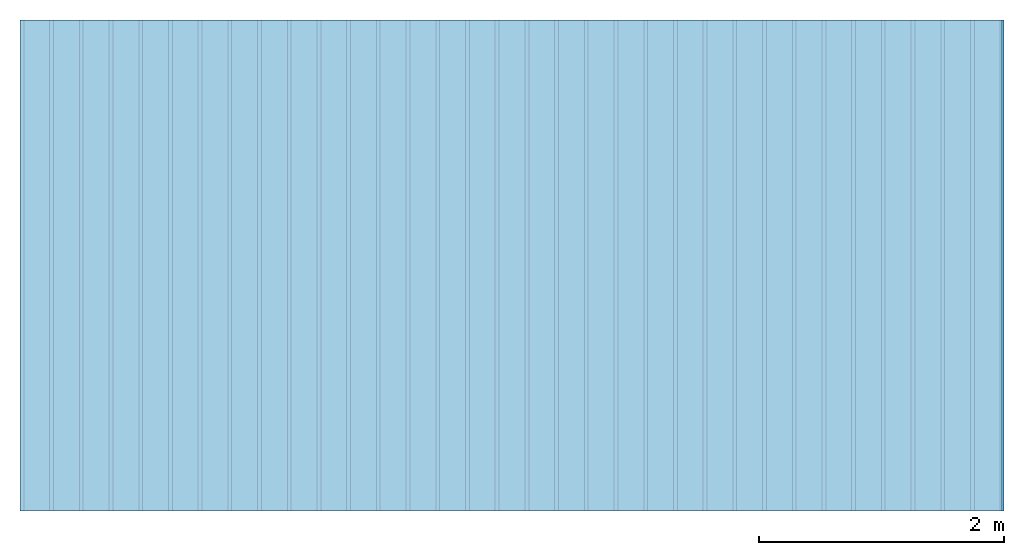
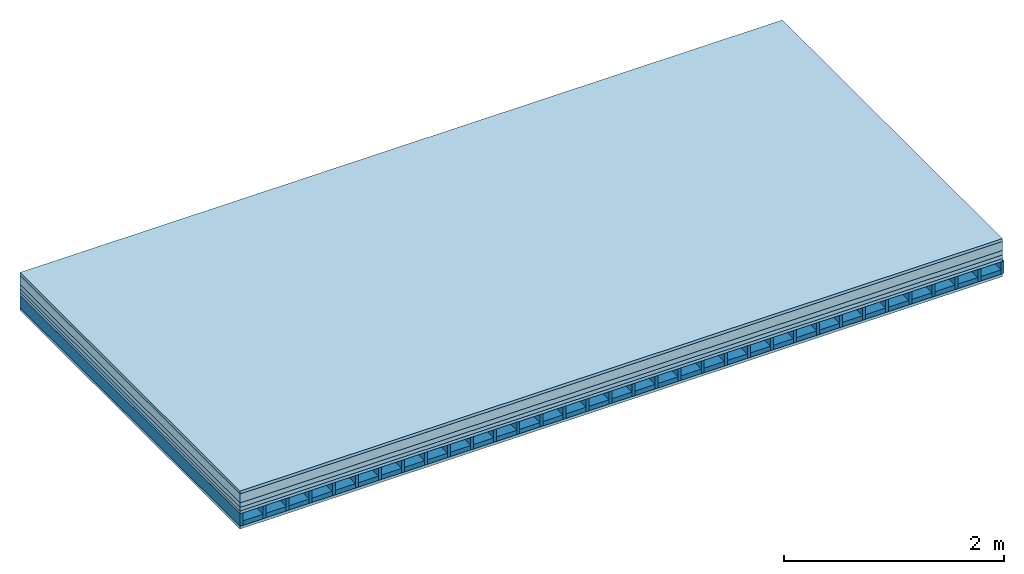
# One storey: 6 plates, 2 members, 1 element without a shape of its own.
"""IFC4 building model written with IfcOpenShell, lengths in metres."""

from ifc_helpers import new_model, si_unit, derived_unit, direction, frame, frame_2d, origin, origin_with_axes, place, context, project, spatial, rectangle, extrude, material, layer, layer_set, type_object, element, aggregate, save


model = new_model("IFC4")

# Units and contexts
plan_context = context("Plan", 3, precision=1e-05, world=origin(), true_north=direction((0.0, 1.0)))
model_context = context("Model", 3, precision=1e-05, world=origin(), true_north=direction((0.0, 1.0)))
ifc_project = project(units=[si_unit("LENGTHUNIT", "METRE"), derived_unit("SOUNDPRESSUREUNIT", [(si_unit("PRESSUREUNIT", "PASCAL", prefix="MICRO"), 0)]), si_unit("ENERGYUNIT", "JOULE", prefix="MEGA"), si_unit("MASSUNIT", "GRAM", prefix="KILO"), derived_unit("THERMALTRANSMITTANCEUNIT", [(si_unit("POWERUNIT", "WATT"), 1), (si_unit("AREAUNIT", "SQUARE_METRE"), -1), (si_unit("THERMODYNAMICTEMPERATUREUNIT", "KELVIN"), -1)]), derived_unit("AREADENSITYUNIT", [(si_unit("MASSUNIT", "GRAM", prefix="KILO"), 1), (si_unit("AREAUNIT", "SQUARE_METRE"), -1)]), derived_unit("USERDEFINED", [(si_unit("ENERGYUNIT", "JOULE", prefix="MEGA"), 1), (si_unit("AREAUNIT", "SQUARE_METRE"), -1)])], contexts=[plan_context, model_context])

# Site, building, storey
site = spatial("IfcSite", under=ifc_project)
building_placement = place(None, origin())
building = spatial("IfcBuilding", under=site, at=building_placement)
storey_placement = place(building_placement, origin())
storey = spatial("IfcBuildingStorey", under=building, at=storey_placement)

# Slab, members, plates
ifc_material_1 = material(Category="03.007")
ifc_layer_1 = layer(ifc_material_1, 0.032, Name="Flooring")
ifc_material_2 = material(Name="screw for hollow floor")
ifc_layer_2 = layer(ifc_material_2, 0.1, Name="layer")
ifc_material_3 = material(Name="Cement screed", Category="04.006")
ifc_layer_3 = layer(ifc_material_3, 0.05, Name="On-material")
ifc_material_4 = material(Name="EP1, 40/35mm")
ifc_layer_4 = layer(ifc_material_4, 0.04, Name="Impact sound insulation")
ifc_material_5 = material(Name="surface element sheathing above")
ifc_layer_5 = layer(ifc_material_5, 0.031, Name="Sub-floor")
ifc_layer_6 = layer(None, 0.138, Name="Supporting structure")
ifc_material_6 = material(Name="surface element sheathing below")
ifc_layer_7 = layer(ifc_material_6, 0.031, Name="Lower layer 1")
ifc_layer_set = layer_set([ifc_layer_1, ifc_layer_2, ifc_layer_3, ifc_layer_4, ifc_layer_5, ifc_layer_6, ifc_layer_7])
slab_type = type_object("IfcSlabType", Name="A2701", PredefinedType="NOTDEFINED", material=ifc_layer_set)
slab_placement = place(None, frame((0.0, 0.0, 0.0), z_axis=(0.0, 0.0, -1.0), x_axis=(1.0, 0.0, 0.0)))
slab = element("IfcSlab", 1, at=slab_placement, inside=storey, type_object=slab_type, material=ifc_layer_set, Name="Slab #1")
ifc_material_7 = material(Name="surface element LFE")
member_1_placement = place(slab_placement, origin())
member_1 = element("IfcMember", 2, at=member_1_placement, material=ifc_material_7, Name="Supporting structure", context=plan_context, shape_type="SweptSolid", body=[
    extrude(rectangle(XDim=0.031, YDim=0.138, at=frame_2d((0.0155, 0.069), x_axis=(1.0, 0.0))), frame((0.0, 4.0, 0.253), z_axis=(0.0, -1.0, 0.0), x_axis=(1.0, 0.0, 0.0)), (0.0, 0.0, 1.0), 4.0),
    extrude(rectangle(XDim=0.031, YDim=0.138, at=frame_2d((0.0155, 0.069), x_axis=(1.0, 0.0))), frame((0.242, 4.0, 0.253), z_axis=(0.0, -1.0, 0.0), x_axis=(1.0, 0.0, 0.0)), (0.0, 0.0, 1.0), 4.0),
    extrude(rectangle(XDim=0.031, YDim=0.138, at=frame_2d((0.0155, 0.069), x_axis=(1.0, 0.0))), frame((0.484, 4.0, 0.253), z_axis=(0.0, -1.0, 0.0), x_axis=(1.0, 0.0, 0.0)), (0.0, 0.0, 1.0), 4.0),
    extrude(rectangle(XDim=0.031, YDim=0.138, at=frame_2d((0.0155, 0.069), x_axis=(1.0, 0.0))), frame((0.726, 4.0, 0.253), z_axis=(0.0, -1.0, 0.0), x_axis=(1.0, 0.0, 0.0)), (0.0, 0.0, 1.0), 4.0),
    extrude(rectangle(XDim=0.031, YDim=0.138, at=frame_2d((0.0155, 0.069), x_axis=(1.0, 0.0))), frame((0.968, 4.0, 0.253), z_axis=(0.0, -1.0, 0.0), x_axis=(1.0, 0.0, 0.0)), (0.0, 0.0, 1.0), 4.0),
    extrude(rectangle(XDim=0.031, YDim=0.138, at=frame_2d((0.0155, 0.069), x_axis=(1.0, 0.0))), frame((1.21, 4.0, 0.253), z_axis=(0.0, -1.0, 0.0), x_axis=(1.0, 0.0, 0.0)), (0.0, 0.0, 1.0), 4.0),
    extrude(rectangle(XDim=0.031, YDim=0.138, at=frame_2d((0.0155, 0.069), x_axis=(1.0, 0.0))), frame((1.452, 4.0, 0.253), z_axis=(0.0, -1.0, 0.0), x_axis=(1.0, 0.0, 0.0)), (0.0, 0.0, 1.0), 4.0),
    extrude(rectangle(XDim=0.031, YDim=0.138, at=frame_2d((0.0155, 0.069), x_axis=(1.0, 0.0))), frame((1.694, 4.0, 0.253), z_axis=(0.0, -1.0, 0.0), x_axis=(1.0, 0.0, 0.0)), (0.0, 0.0, 1.0), 4.0),
    extrude(rectangle(XDim=0.031, YDim=0.138, at=frame_2d((0.0155, 0.069), x_axis=(1.0, 0.0))), frame((1.936, 4.0, 0.253), z_axis=(0.0, -1.0, 0.0), x_axis=(1.0, 0.0, 0.0)), (0.0, 0.0, 1.0), 4.0),
    extrude(rectangle(XDim=0.031, YDim=0.138, at=frame_2d((0.0155, 0.069), x_axis=(1.0, 0.0))), frame((2.178, 4.0, 0.253), z_axis=(0.0, -1.0, 0.0), x_axis=(1.0, 0.0, 0.0)), (0.0, 0.0, 1.0), 4.0),
    extrude(rectangle(XDim=0.031, YDim=0.138, at=frame_2d((0.0155, 0.069), x_axis=(1.0, 0.0))), frame((2.42, 4.0, 0.253), z_axis=(0.0, -1.0, 0.0), x_axis=(1.0, 0.0, 0.0)), (0.0, 0.0, 1.0), 4.0),
    extrude(rectangle(XDim=0.031, YDim=0.138, at=frame_2d((0.0155, 0.069), x_axis=(1.0, 0.0))), frame((2.662, 4.0, 0.253), z_axis=(0.0, -1.0, 0.0), x_axis=(1.0, 0.0, 0.0)), (0.0, 0.0, 1.0), 4.0),
    extrude(rectangle(XDim=0.031, YDim=0.138, at=frame_2d((0.0155, 0.069), x_axis=(1.0, 0.0))), frame((2.904, 4.0, 0.253), z_axis=(0.0, -1.0, 0.0), x_axis=(1.0, 0.0, 0.0)), (0.0, 0.0, 1.0), 4.0),
    extrude(rectangle(XDim=0.031, YDim=0.138, at=frame_2d((0.0155, 0.069), x_axis=(1.0, 0.0))), frame((3.146, 4.0, 0.253), z_axis=(0.0, -1.0, 0.0), x_axis=(1.0, 0.0, 0.0)), (0.0, 0.0, 1.0), 4.0),
    extrude(rectangle(XDim=0.031, YDim=0.138, at=frame_2d((0.0155, 0.069), x_axis=(1.0, 0.0))), frame((3.388, 4.0, 0.253), z_axis=(0.0, -1.0, 0.0), x_axis=(1.0, 0.0, 0.0)), (0.0, 0.0, 1.0), 4.0),
    extrude(rectangle(XDim=0.031, YDim=0.138, at=frame_2d((0.0155, 0.069), x_axis=(1.0, 0.0))), frame((3.63, 4.0, 0.253), z_axis=(0.0, -1.0, 0.0), x_axis=(1.0, 0.0, 0.0)), (0.0, 0.0, 1.0), 4.0),
    extrude(rectangle(XDim=0.031, YDim=0.138, at=frame_2d((0.0155, 0.069), x_axis=(1.0, 0.0))), frame((3.872, 4.0, 0.253), z_axis=(0.0, -1.0, 0.0), x_axis=(1.0, 0.0, 0.0)), (0.0, 0.0, 1.0), 4.0),
    extrude(rectangle(XDim=0.031, YDim=0.138, at=frame_2d((0.0155, 0.069), x_axis=(1.0, 0.0))), frame((4.114, 4.0, 0.253), z_axis=(0.0, -1.0, 0.0), x_axis=(1.0, 0.0, 0.0)), (0.0, 0.0, 1.0), 4.0),
    extrude(rectangle(XDim=0.031, YDim=0.138, at=frame_2d((0.0155, 0.069), x_axis=(1.0, 0.0))), frame((4.356, 4.0, 0.253), z_axis=(0.0, -1.0, 0.0), x_axis=(1.0, 0.0, 0.0)), (0.0, 0.0, 1.0), 4.0),
    extrude(rectangle(XDim=0.031, YDim=0.138, at=frame_2d((0.0155, 0.069), x_axis=(1.0, 0.0))), frame((4.598, 4.0, 0.253), z_axis=(0.0, -1.0, 0.0), x_axis=(1.0, 0.0, 0.0)), (0.0, 0.0, 1.0), 4.0),
    extrude(rectangle(XDim=0.031, YDim=0.138, at=frame_2d((0.0155, 0.069), x_axis=(1.0, 0.0))), frame((4.84, 4.0, 0.253), z_axis=(0.0, -1.0, 0.0), x_axis=(1.0, 0.0, 0.0)), (0.0, 0.0, 1.0), 4.0),
    extrude(rectangle(XDim=0.031, YDim=0.138, at=frame_2d((0.0155, 0.069), x_axis=(1.0, 0.0))), frame((5.082, 4.0, 0.253), z_axis=(0.0, -1.0, 0.0), x_axis=(1.0, 0.0, 0.0)), (0.0, 0.0, 1.0), 4.0),
    extrude(rectangle(XDim=0.031, YDim=0.138, at=frame_2d((0.0155, 0.069), x_axis=(1.0, 0.0))), frame((5.324, 4.0, 0.253), z_axis=(0.0, -1.0, 0.0), x_axis=(1.0, 0.0, 0.0)), (0.0, 0.0, 1.0), 4.0),
    extrude(rectangle(XDim=0.031, YDim=0.138, at=frame_2d((0.0155, 0.069), x_axis=(1.0, 0.0))), frame((5.566, 4.0, 0.253), z_axis=(0.0, -1.0, 0.0), x_axis=(1.0, 0.0, 0.0)), (0.0, 0.0, 1.0), 4.0),
    extrude(rectangle(XDim=0.031, YDim=0.138, at=frame_2d((0.0155, 0.069), x_axis=(1.0, 0.0))), frame((5.808, 4.0, 0.253), z_axis=(0.0, -1.0, 0.0), x_axis=(1.0, 0.0, 0.0)), (0.0, 0.0, 1.0), 4.0),
    extrude(rectangle(XDim=0.031, YDim=0.138, at=frame_2d((0.0155, 0.069), x_axis=(1.0, 0.0))), frame((6.05, 4.0, 0.253), z_axis=(0.0, -1.0, 0.0), x_axis=(1.0, 0.0, 0.0)), (0.0, 0.0, 1.0), 4.0),
    extrude(rectangle(XDim=0.031, YDim=0.138, at=frame_2d((0.0155, 0.069), x_axis=(1.0, 0.0))), frame((6.292, 4.0, 0.253), z_axis=(0.0, -1.0, 0.0), x_axis=(1.0, 0.0, 0.0)), (0.0, 0.0, 1.0), 4.0),
    extrude(rectangle(XDim=0.031, YDim=0.138, at=frame_2d((0.0155, 0.069), x_axis=(1.0, 0.0))), frame((6.534, 4.0, 0.253), z_axis=(0.0, -1.0, 0.0), x_axis=(1.0, 0.0, 0.0)), (0.0, 0.0, 1.0), 4.0),
    extrude(rectangle(XDim=0.031, YDim=0.138, at=frame_2d((0.0155, 0.069), x_axis=(1.0, 0.0))), frame((6.776, 4.0, 0.253), z_axis=(0.0, -1.0, 0.0), x_axis=(1.0, 0.0, 0.0)), (0.0, 0.0, 1.0), 4.0),
    extrude(rectangle(XDim=0.031, YDim=0.138, at=frame_2d((0.0155, 0.069), x_axis=(1.0, 0.0))), frame((7.018, 4.0, 0.253), z_axis=(0.0, -1.0, 0.0), x_axis=(1.0, 0.0, 0.0)), (0.0, 0.0, 1.0), 4.0),
    extrude(rectangle(XDim=0.031, YDim=0.138, at=frame_2d((0.0155, 0.069), x_axis=(1.0, 0.0))), frame((7.26, 4.0, 0.253), z_axis=(0.0, -1.0, 0.0), x_axis=(1.0, 0.0, 0.0)), (0.0, 0.0, 1.0), 4.0),
    extrude(rectangle(XDim=0.031, YDim=0.138, at=frame_2d((0.0155, 0.069), x_axis=(1.0, 0.0))), frame((7.502, 4.0, 0.253), z_axis=(0.0, -1.0, 0.0), x_axis=(1.0, 0.0, 0.0)), (0.0, 0.0, 1.0), 4.0),
    extrude(rectangle(XDim=0.031, YDim=0.138, at=frame_2d((0.0155, 0.069), x_axis=(1.0, 0.0))), frame((7.744, 4.0, 0.253), z_axis=(0.0, -1.0, 0.0), x_axis=(1.0, 0.0, 0.0)), (0.0, 0.0, 1.0), 4.0),
    extrude(rectangle(XDim=0.031, YDim=0.138, at=frame_2d((0.0155, 0.069), x_axis=(1.0, 0.0))), frame((7.986, 4.0, 0.253), z_axis=(0.0, -1.0, 0.0), x_axis=(1.0, 0.0, 0.0)), (0.0, 0.0, 1.0), 4.0),
])
ifc_material_8 = material()
member_2_placement = place(slab_placement, origin())
member_2 = element("IfcMember", 3, at=member_2_placement, material=ifc_material_8, Name="in supporting structure", context=plan_context, shape_type="SweptSolid", body=[
    extrude(rectangle(XDim=0.211, YDim=0.049, at=frame_2d((0.1055, 0.0245), x_axis=(1.0, 0.0))), frame((0.031, 4.0, 0.342), z_axis=(0.0, -1.0, 0.0), x_axis=(1.0, 0.0, 0.0)), (0.0, 0.0, 1.0), 4.0),
    extrude(rectangle(XDim=0.211, YDim=0.049, at=frame_2d((0.1055, 0.0245), x_axis=(1.0, 0.0))), frame((0.273, 4.0, 0.342), z_axis=(0.0, -1.0, 0.0), x_axis=(1.0, 0.0, 0.0)), (0.0, 0.0, 1.0), 4.0),
    extrude(rectangle(XDim=0.211, YDim=0.049, at=frame_2d((0.1055, 0.0245), x_axis=(1.0, 0.0))), frame((0.515, 4.0, 0.342), z_axis=(0.0, -1.0, 0.0), x_axis=(1.0, 0.0, 0.0)), (0.0, 0.0, 1.0), 4.0),
    extrude(rectangle(XDim=0.211, YDim=0.049, at=frame_2d((0.1055, 0.0245), x_axis=(1.0, 0.0))), frame((0.757, 4.0, 0.342), z_axis=(0.0, -1.0, 0.0), x_axis=(1.0, 0.0, 0.0)), (0.0, 0.0, 1.0), 4.0),
    extrude(rectangle(XDim=0.211, YDim=0.049, at=frame_2d((0.1055, 0.0245), x_axis=(1.0, 0.0))), frame((0.999, 4.0, 0.342), z_axis=(0.0, -1.0, 0.0), x_axis=(1.0, 0.0, 0.0)), (0.0, 0.0, 1.0), 4.0),
    extrude(rectangle(XDim=0.211, YDim=0.049, at=frame_2d((0.1055, 0.0245), x_axis=(1.0, 0.0))), frame((1.241, 4.0, 0.342), z_axis=(0.0, -1.0, 0.0), x_axis=(1.0, 0.0, 0.0)), (0.0, 0.0, 1.0), 4.0),
    extrude(rectangle(XDim=0.211, YDim=0.049, at=frame_2d((0.1055, 0.0245), x_axis=(1.0, 0.0))), frame((1.483, 4.0, 0.342), z_axis=(0.0, -1.0, 0.0), x_axis=(1.0, 0.0, 0.0)), (0.0, 0.0, 1.0), 4.0),
    extrude(rectangle(XDim=0.211, YDim=0.049, at=frame_2d((0.1055, 0.0245), x_axis=(1.0, 0.0))), frame((1.725, 4.0, 0.342), z_axis=(0.0, -1.0, 0.0), x_axis=(1.0, 0.0, 0.0)), (0.0, 0.0, 1.0), 4.0),
    extrude(rectangle(XDim=0.211, YDim=0.049, at=frame_2d((0.1055, 0.0245), x_axis=(1.0, 0.0))), frame((1.967, 4.0, 0.342), z_axis=(0.0, -1.0, 0.0), x_axis=(1.0, 0.0, 0.0)), (0.0, 0.0, 1.0), 4.0),
    extrude(rectangle(XDim=0.211, YDim=0.049, at=frame_2d((0.1055, 0.0245), x_axis=(1.0, 0.0))), frame((2.209, 4.0, 0.342), z_axis=(0.0, -1.0, 0.0), x_axis=(1.0, 0.0, 0.0)), (0.0, 0.0, 1.0), 4.0),
    extrude(rectangle(XDim=0.211, YDim=0.049, at=frame_2d((0.1055, 0.0245), x_axis=(1.0, 0.0))), frame((2.451, 4.0, 0.342), z_axis=(0.0, -1.0, 0.0), x_axis=(1.0, 0.0, 0.0)), (0.0, 0.0, 1.0), 4.0),
    extrude(rectangle(XDim=0.211, YDim=0.049, at=frame_2d((0.1055, 0.0245), x_axis=(1.0, 0.0))), frame((2.693, 4.0, 0.342), z_axis=(0.0, -1.0, 0.0), x_axis=(1.0, 0.0, 0.0)), (0.0, 0.0, 1.0), 4.0),
    extrude(rectangle(XDim=0.211, YDim=0.049, at=frame_2d((0.1055, 0.0245), x_axis=(1.0, 0.0))), frame((2.935, 4.0, 0.342), z_axis=(0.0, -1.0, 0.0), x_axis=(1.0, 0.0, 0.0)), (0.0, 0.0, 1.0), 4.0),
    extrude(rectangle(XDim=0.211, YDim=0.049, at=frame_2d((0.1055, 0.0245), x_axis=(1.0, 0.0))), frame((3.177, 4.0, 0.342), z_axis=(0.0, -1.0, 0.0), x_axis=(1.0, 0.0, 0.0)), (0.0, 0.0, 1.0), 4.0),
    extrude(rectangle(XDim=0.211, YDim=0.049, at=frame_2d((0.1055, 0.0245), x_axis=(1.0, 0.0))), frame((3.419, 4.0, 0.342), z_axis=(0.0, -1.0, 0.0), x_axis=(1.0, 0.0, 0.0)), (0.0, 0.0, 1.0), 4.0),
    extrude(rectangle(XDim=0.211, YDim=0.049, at=frame_2d((0.1055, 0.0245), x_axis=(1.0, 0.0))), frame((3.661, 4.0, 0.342), z_axis=(0.0, -1.0, 0.0), x_axis=(1.0, 0.0, 0.0)), (0.0, 0.0, 1.0), 4.0),
    extrude(rectangle(XDim=0.211, YDim=0.049, at=frame_2d((0.1055, 0.0245), x_axis=(1.0, 0.0))), frame((3.903, 4.0, 0.342), z_axis=(0.0, -1.0, 0.0), x_axis=(1.0, 0.0, 0.0)), (0.0, 0.0, 1.0), 4.0),
    extrude(rectangle(XDim=0.211, YDim=0.049, at=frame_2d((0.1055, 0.0245), x_axis=(1.0, 0.0))), frame((4.145, 4.0, 0.342), z_axis=(0.0, -1.0, 0.0), x_axis=(1.0, 0.0, 0.0)), (0.0, 0.0, 1.0), 4.0),
    extrude(rectangle(XDim=0.211, YDim=0.049, at=frame_2d((0.1055, 0.0245), x_axis=(1.0, 0.0))), frame((4.387, 4.0, 0.342), z_axis=(0.0, -1.0, 0.0), x_axis=(1.0, 0.0, 0.0)), (0.0, 0.0, 1.0), 4.0),
    extrude(rectangle(XDim=0.211, YDim=0.049, at=frame_2d((0.1055, 0.0245), x_axis=(1.0, 0.0))), frame((4.629, 4.0, 0.342), z_axis=(0.0, -1.0, 0.0), x_axis=(1.0, 0.0, 0.0)), (0.0, 0.0, 1.0), 4.0),
    extrude(rectangle(XDim=0.211, YDim=0.049, at=frame_2d((0.1055, 0.0245), x_axis=(1.0, 0.0))), frame((4.871, 4.0, 0.342), z_axis=(0.0, -1.0, 0.0), x_axis=(1.0, 0.0, 0.0)), (0.0, 0.0, 1.0), 4.0),
    extrude(rectangle(XDim=0.211, YDim=0.049, at=frame_2d((0.1055, 0.0245), x_axis=(1.0, 0.0))), frame((5.113, 4.0, 0.342), z_axis=(0.0, -1.0, 0.0), x_axis=(1.0, 0.0, 0.0)), (0.0, 0.0, 1.0), 4.0),
    extrude(rectangle(XDim=0.211, YDim=0.049, at=frame_2d((0.1055, 0.0245), x_axis=(1.0, 0.0))), frame((5.355, 4.0, 0.342), z_axis=(0.0, -1.0, 0.0), x_axis=(1.0, 0.0, 0.0)), (0.0, 0.0, 1.0), 4.0),
    extrude(rectangle(XDim=0.211, YDim=0.049, at=frame_2d((0.1055, 0.0245), x_axis=(1.0, 0.0))), frame((5.597, 4.0, 0.342), z_axis=(0.0, -1.0, 0.0), x_axis=(1.0, 0.0, 0.0)), (0.0, 0.0, 1.0), 4.0),
    extrude(rectangle(XDim=0.211, YDim=0.049, at=frame_2d((0.1055, 0.0245), x_axis=(1.0, 0.0))), frame((5.839, 4.0, 0.342), z_axis=(0.0, -1.0, 0.0), x_axis=(1.0, 0.0, 0.0)), (0.0, 0.0, 1.0), 4.0),
    extrude(rectangle(XDim=0.211, YDim=0.049, at=frame_2d((0.1055, 0.0245), x_axis=(1.0, 0.0))), frame((6.081, 4.0, 0.342), z_axis=(0.0, -1.0, 0.0), x_axis=(1.0, 0.0, 0.0)), (0.0, 0.0, 1.0), 4.0),
    extrude(rectangle(XDim=0.211, YDim=0.049, at=frame_2d((0.1055, 0.0245), x_axis=(1.0, 0.0))), frame((6.323, 4.0, 0.342), z_axis=(0.0, -1.0, 0.0), x_axis=(1.0, 0.0, 0.0)), (0.0, 0.0, 1.0), 4.0),
    extrude(rectangle(XDim=0.211, YDim=0.049, at=frame_2d((0.1055, 0.0245), x_axis=(1.0, 0.0))), frame((6.565, 4.0, 0.342), z_axis=(0.0, -1.0, 0.0), x_axis=(1.0, 0.0, 0.0)), (0.0, 0.0, 1.0), 4.0),
    extrude(rectangle(XDim=0.211, YDim=0.049, at=frame_2d((0.1055, 0.0245), x_axis=(1.0, 0.0))), frame((6.807, 4.0, 0.342), z_axis=(0.0, -1.0, 0.0), x_axis=(1.0, 0.0, 0.0)), (0.0, 0.0, 1.0), 4.0),
    extrude(rectangle(XDim=0.211, YDim=0.049, at=frame_2d((0.1055, 0.0245), x_axis=(1.0, 0.0))), frame((7.049, 4.0, 0.342), z_axis=(0.0, -1.0, 0.0), x_axis=(1.0, 0.0, 0.0)), (0.0, 0.0, 1.0), 4.0),
    extrude(rectangle(XDim=0.211, YDim=0.049, at=frame_2d((0.1055, 0.0245), x_axis=(1.0, 0.0))), frame((7.291, 4.0, 0.342), z_axis=(0.0, -1.0, 0.0), x_axis=(1.0, 0.0, 0.0)), (0.0, 0.0, 1.0), 4.0),
    extrude(rectangle(XDim=0.211, YDim=0.049, at=frame_2d((0.1055, 0.0245), x_axis=(1.0, 0.0))), frame((7.533, 4.0, 0.342), z_axis=(0.0, -1.0, 0.0), x_axis=(1.0, 0.0, 0.0)), (0.0, 0.0, 1.0), 4.0),
    extrude(rectangle(XDim=0.211, YDim=0.049, at=frame_2d((0.1055, 0.0245), x_axis=(1.0, 0.0))), frame((7.775, 4.0, 0.342), z_axis=(0.0, -1.0, 0.0), x_axis=(1.0, 0.0, 0.0)), (0.0, 0.0, 1.0), 4.0),
])
plate_1_placement = place(slab_placement, origin())
plate_1 = element("IfcPlate", 4, at=plate_1_placement, material=ifc_material_1, Name="Flooring", context=plan_context, shape_type="SweptSolid", body=[
    extrude(rectangle(XDim=8.0, YDim=4.0, at=frame_2d((4.0, 2.0), x_axis=(1.0, 0.0))), origin_with_axes(), (0.0, 0.0, 1.0), 0.032),
])
plate_2_placement = place(slab_placement, origin())
plate_2 = element("IfcPlate", 5, at=plate_2_placement, material=ifc_material_2, Name="layer", context=plan_context, shape_type="SweptSolid", body=[
    extrude(rectangle(XDim=8.0, YDim=4.0, at=frame_2d((4.0, 2.0), x_axis=(1.0, 0.0))), frame((0.0, 0.0, 0.032), z_axis=(0.0, 0.0, 1.0), x_axis=(1.0, 0.0, 0.0)), (0.0, 0.0, 1.0), 0.1),
])
plate_3_placement = place(slab_placement, origin())
plate_3 = element("IfcPlate", 6, at=plate_3_placement, material=ifc_material_3, Name="On-material", context=plan_context, shape_type="SweptSolid", body=[
    extrude(rectangle(XDim=8.0, YDim=4.0, at=frame_2d((4.0, 2.0), x_axis=(1.0, 0.0))), frame((0.0, 0.0, 0.132), z_axis=(0.0, 0.0, 1.0), x_axis=(1.0, 0.0, 0.0)), (0.0, 0.0, 1.0), 0.05),
])
plate_4_placement = place(slab_placement, origin())
plate_4 = element("IfcPlate", 7, at=plate_4_placement, material=ifc_material_4, Name="Impact sound insulation", context=plan_context, shape_type="SweptSolid", body=[
    extrude(rectangle(XDim=8.0, YDim=4.0, at=frame_2d((4.0, 2.0), x_axis=(1.0, 0.0))), frame((0.0, 0.0, 0.182), z_axis=(0.0, 0.0, 1.0), x_axis=(1.0, 0.0, 0.0)), (0.0, 0.0, 1.0), 0.04),
])
plate_5_placement = place(slab_placement, origin())
plate_5 = element("IfcPlate", 8, at=plate_5_placement, material=ifc_material_5, Name="Sub-floor", context=plan_context, shape_type="SweptSolid", body=[
    extrude(rectangle(XDim=8.0, YDim=4.0, at=frame_2d((4.0, 2.0), x_axis=(1.0, 0.0))), frame((0.0, 0.0, 0.222), z_axis=(0.0, 0.0, 1.0), x_axis=(1.0, 0.0, 0.0)), (0.0, 0.0, 1.0), 0.031),
])
plate_6_placement = place(slab_placement, origin())
plate_6 = element("IfcPlate", 9, at=plate_6_placement, material=ifc_material_6, Name="Lower layer 1", context=plan_context, shape_type="SweptSolid", body=[
    extrude(rectangle(XDim=8.0, YDim=4.0, at=frame_2d((4.0, 2.0), x_axis=(1.0, 0.0))), frame((0.0, 0.0, 0.391), z_axis=(0.0, 0.0, 1.0), x_axis=(1.0, 0.0, 0.0)), (0.0, 0.0, 1.0), 0.031),
])
aggregate(slab, [plate_1, plate_2, plate_3, plate_4, plate_5, member_1, member_2, plate_6])

save(model, "model.ifc")
